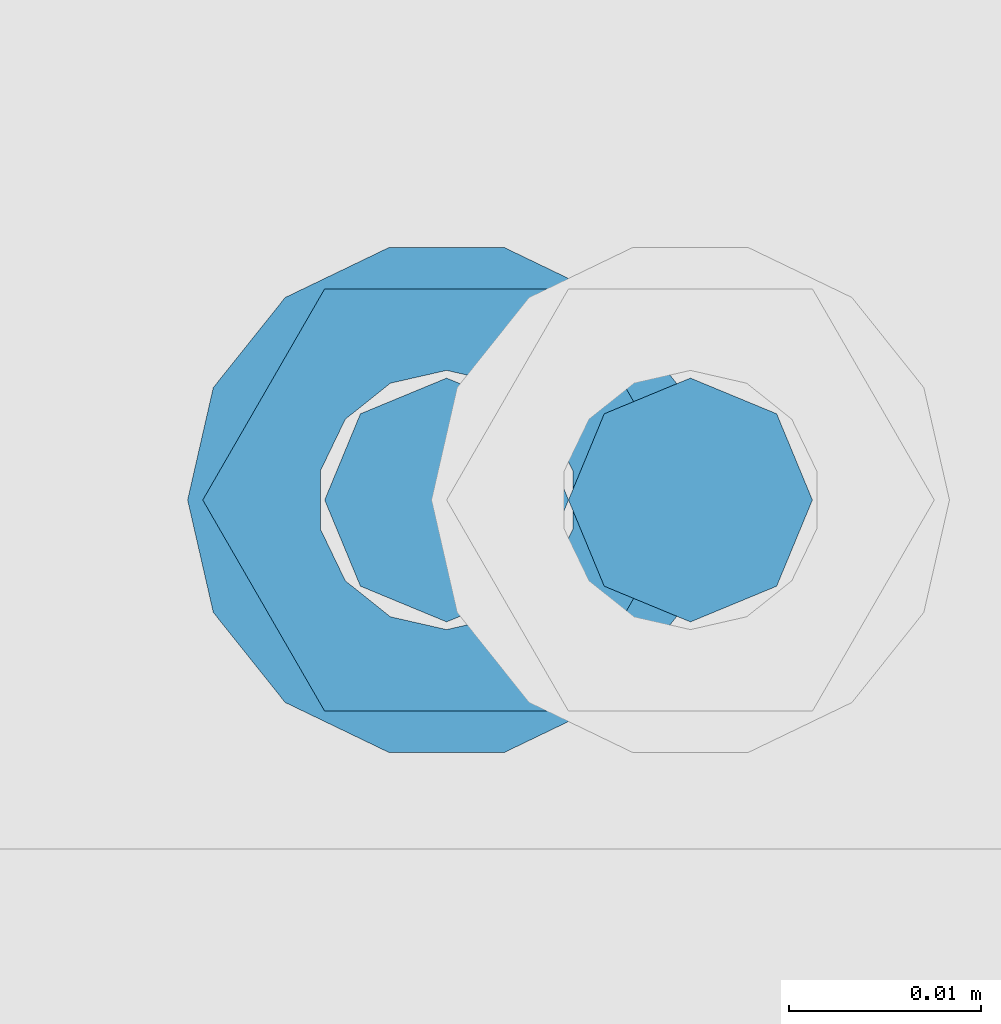
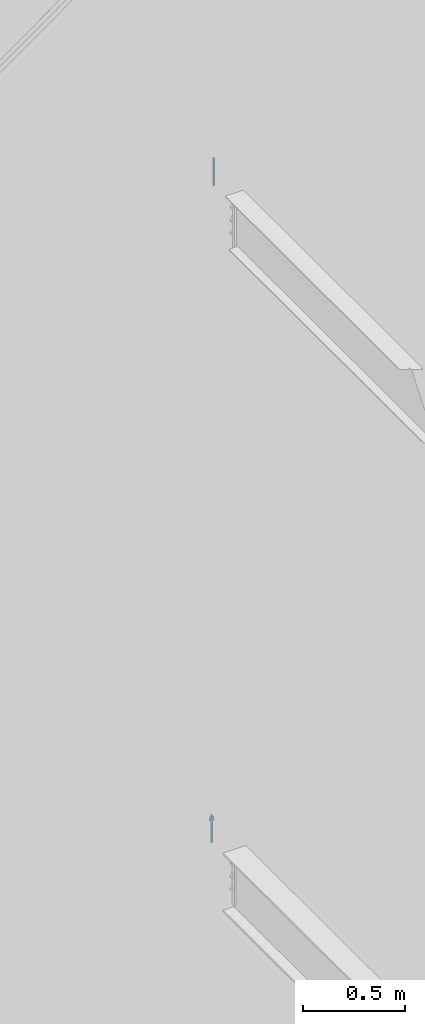
# One storey, part 564 of 1179: 2 columns, 2 elements without a shape of their own.
"""IFC2X3 building model written with IfcOpenShell, lengths in millimetres."""

import ifcopenshell
import ifcopenshell.guid

model = None  # the IFC model being written
_history = None  # IfcOwnerHistory: only IFC2X3 demands one
_inside = {}  # id of a spatial element -> (the spatial element, [elements in it])
_under = {}  # id of a project, library or spatial element -> (it, [spatial elements below it])
_declared = {}  # id of a project -> (the project, [libraries it declares])
_typed = {}  # id of a type object -> (the type object, [elements of that type])
_made_of = {}  # id of a material, layer set ... -> (it, [elements and type objects made of it])


def new_model(schema):
    """Start an empty IFC model of exactly this schema.

    Asked for "IFC4X3", IfcOpenShell would pick the latest addendum, in which some entities
    have other attributes; the version numbers below select the first issue.
    IFC2X3 requires an IfcOwnerHistory on every rooted entity: one is made here for all.
    """
    global model, _history
    if schema == "IFC4X3":
        model = ifcopenshell.file(schema_version=(4, 3, 0, 0))
    else:
        model = ifcopenshell.file(schema=schema)
    _inside.clear()
    _under.clear()
    _declared.clear()
    _typed.clear()
    _made_of.clear()
    _history = None
    if model.schema == "IFC2X3":
        org = make("IfcOrganization", Name="unknown")
        user = make(
            "IfcPersonAndOrganization",
            ThePerson=make("IfcPerson", FamilyName="unknown"),
            TheOrganization=org,
        )
        app = make(
            "IfcApplication",
            ApplicationDeveloper=org,
            Version="unknown",
            ApplicationFullName="unknown",
            ApplicationIdentifier="unknown",
        )
        _history = make(
            "IfcOwnerHistory",
            OwningUser=user,
            OwningApplication=app,
            ChangeAction="ADDED",
            CreationDate=0,
        )
    return model


def make(cls, **values):
    """One entity of the class cls with the attributes given. An attribute that is None is left unset."""
    return model.create_entity(
        cls, **{name: value for name, value in values.items() if value is not None}
    )


def rooted(cls, **values):
    """An entity with a GlobalId (a new one), such as an element, a storey or a relation."""
    return make(cls, GlobalId=ifcopenshell.guid.new(), OwnerHistory=_history, **values)


def si_unit(unit_type, name, prefix=None):
    """IfcSIUnit, for example si_unit("LENGTHUNIT", "METRE", prefix="MILLI")."""
    return make("IfcSIUnit", UnitType=unit_type, Prefix=prefix, Name=name)


def assignment(units):
    """IfcUnitAssignment: the units of a project."""
    return None if units is None else make("IfcUnitAssignment", Units=units)


def point(xyz):
    """IfcCartesianPoint."""
    return None if xyz is None else make("IfcCartesianPoint", Coordinates=xyz)


def direction(xyz):
    """IfcDirection."""
    return None if xyz is None else make("IfcDirection", DirectionRatios=xyz)


def frame(location, z_axis=None, x_axis=None):
    """IfcAxis2Placement3D, a coordinate frame: its origin and axes. An axis left out is left unset."""
    return make(
        "IfcAxis2Placement3D",
        Location=point(location),
        Axis=direction(z_axis),
        RefDirection=direction(x_axis),
    )


def origin_with_axes():
    """The frame at (0, 0, 0) with the z axis (0, 0, 1) and the x axis (1, 0, 0) written out."""
    return frame((0.0, 0.0, 0.0), z_axis=(0.0, 0.0, 1.0), x_axis=(1.0, 0.0, 0.0))


def place(relative_to, where):
    """IfcLocalPlacement: puts the frame where relative to a parent placement (None: the world)."""
    return make(
        "IfcLocalPlacement", PlacementRelTo=relative_to, RelativePlacement=where
    )


def context(
    kind, dimensions, precision=None, world=None, true_north=None, identifier=None
):
    """IfcGeometricRepresentationContext, for example the 3D "Model" context."""
    return make(
        "IfcGeometricRepresentationContext",
        ContextIdentifier=identifier,
        ContextType=kind,
        CoordinateSpaceDimension=dimensions,
        Precision=precision,
        WorldCoordinateSystem=world,
        TrueNorth=true_north,
    )


def subcontext(parent, identifier, kind, view, scale=None):
    """IfcGeometricRepresentationSubContext, for example "Body" below "Model"."""
    return make(
        "IfcGeometricRepresentationSubContext",
        ContextIdentifier=identifier,
        ContextType=kind,
        ParentContext=parent,
        TargetScale=scale,
        TargetView=view,
    )


def project(units=None, contexts=None):
    """IfcProject with its units and contexts."""
    return rooted(
        "IfcProject",
        Name="project",
        RepresentationContexts=contexts,
        UnitsInContext=assignment(units),
    )


def spatial(cls, under=None, at=None, **own):
    """A site, building, storey or space (cls), placed at a placement, below another one or the project."""
    s = rooted(cls, ObjectPlacement=at, **own)
    if under is not None:
        _under.setdefault(under.id(), (under, []))[1].append(s)
    return s


def faces_of(points, faces, orient=None, outer=None):
    """IfcFace entities. A face is a list of loops; a loop is a list of indices into points, from 0.

    orient and outer hold one flag for each loop. By default every Orientation is true, the
    first loop of a face is its IfcFaceOuterBound and the others are IfcFaceBound.
    """
    made = []
    for i, loops in enumerate(faces):
        bounds = []
        for j, loop in enumerate(loops):
            is_outer = j == 0 if outer is None else outer[i][j]
            bounds.append(
                make(
                    "IfcFaceOuterBound" if is_outer else "IfcFaceBound",
                    Bound=make("IfcPolyLoop", Polygon=[points[k] for k in loop]),
                    Orientation=True if orient is None else orient[i][j],
                )
            )
        made.append(make("IfcFace", Bounds=bounds))
    return made


def faceted_brep(points, faces, orient=None, outer=None, voids=None):
    """IfcFacetedBrep: a solid bounded by flat faces; with voids (closed shells), ...WithVoids."""
    shared = [point(p) for p in points]
    hull = make("IfcClosedShell", CfsFaces=faces_of(shared, faces, orient, outer))
    if voids is None:
        return make("IfcFacetedBrep", Outer=hull)
    return make(
        "IfcFacetedBrepWithVoids",
        Outer=hull,
        Voids=[
            make(cls, CfsFaces=faces_of(shared, fs, o, b)) for cls, fs, o, b in voids
        ],
    )


def shape(context_of_items, identifier, shape_type, items):
    """IfcShapeRepresentation: the items that make up one representation, for example the "Body"."""
    return make(
        "IfcShapeRepresentation",
        ContextOfItems=context_of_items,
        RepresentationIdentifier=identifier,
        RepresentationType=shape_type,
        Items=items,
    )


def material(Name=None, Category=None):
    """IfcMaterial."""
    return make("IfcMaterial", Name=Name, Category=Category)


def made_of(thing, what):
    """Note that an element or type object is made of a material, layer set ...; save() writes the relation."""
    if what is not None:
        _made_of.setdefault(what.id(), (what, []))[1].append(thing)
    return thing


def type_object(cls, material=None, **own):
    """A type object (cls), such as IfcWallType, which elements share."""
    return made_of(rooted(cls, **own), material)


def element(
    cls,
    number,
    at=None,
    inside=None,
    cuts=None,
    type_object=None,
    material=None,
    context=None,
    identifier="Body",
    shape_type=None,
    held_by="IfcProductDefinitionShape",
    body=None,
    shapes=None,
    **own,
):
    """One element of the class cls, such as IfcWall. Its Tag is "e" and its number.

    at: its placement. inside: the storey or other place that contains it. cuts: it is an
    opening in that element (IfcRelVoidsElement). A single representation is given by context,
    identifier, shape_type and body (its items); several are given by shapes. held_by: the class
    of the entity that holds the representations. save() writes the other relations.
    """
    e = rooted(cls, Tag="e%d" % number, ObjectPlacement=at, **own)
    if body is not None:
        shapes = [shape(context, identifier, shape_type, body)]
    if shapes is not None:
        e.Representation = make(held_by, Representations=shapes)
    if inside is not None:
        _inside.setdefault(inside.id(), (inside, []))[1].append(e)
    if cuts is not None:
        rooted(
            "IfcRelVoidsElement", RelatingBuildingElement=cuts, RelatedOpeningElement=e
        )
    if type_object is not None:
        _typed.setdefault(type_object.id(), (type_object, []))[1].append(e)
    return made_of(e, material)


def aggregate(whole, parts):
    """IfcRelAggregates: a whole, such as a stair, and the parts it consists of."""
    return rooted("IfcRelAggregates", RelatingObject=whole, RelatedObjects=parts)


def save(model, path):
    """Write the relations noted so far, then the file.

    IfcRelAggregates (storeys below a building ...), IfcRelContainedInSpatialStructure (elements
    in a storey), IfcRelDefinesByType, IfcRelAssociatesMaterial and IfcRelDeclares: one each for
    every whole, place, type object, material and project.
    """
    for whole, parts in _under.values():
        aggregate(whole, parts)
    for where, things in _inside.values():
        rooted(
            "IfcRelContainedInSpatialStructure",
            RelatedElements=things,
            RelatingStructure=where,
        )
    for kind, things in _typed.values():
        rooted("IfcRelDefinesByType", RelatedObjects=things, RelatingType=kind)
    for what, things in _made_of.values():
        rooted("IfcRelAssociatesMaterial", RelatedObjects=things, RelatingMaterial=what)
    for by, libraries in _declared.values():
        rooted("IfcRelDeclares", RelatingContext=by, RelatedDefinitions=libraries)
    model.write(path)


model = new_model("IFC2X3")

# Units and contexts
model_context = context("Model", 3, precision=1e-05, world=origin_with_axes())
body_context = subcontext(model_context, "Body", "Model", "MODEL_VIEW")
ifc_project = project(units=[si_unit("LENGTHUNIT", "METRE", prefix="MILLI"), si_unit("AREAUNIT", "SQUARE_METRE"), si_unit("VOLUMEUNIT", "CUBIC_METRE"), si_unit("MASSUNIT", "GRAM", prefix="KILO"), si_unit("TIMEUNIT", "SECOND"), si_unit("PLANEANGLEUNIT", "RADIAN"), si_unit("SOLIDANGLEUNIT", "STERADIAN"), si_unit("THERMODYNAMICTEMPERATUREUNIT", "DEGREE_CELSIUS"), si_unit("LUMINOUSINTENSITYUNIT", "LUMEN")], contexts=[model_context])

# Site, building, storey
site_placement = place(None, origin_with_axes())
site = spatial("IfcSite", under=ifc_project, at=site_placement, CompositionType="ELEMENT")
building_placement = place(site_placement, origin_with_axes())
building = spatial("IfcBuilding", under=site, at=building_placement, Name="Undefined", CompositionType="ELEMENT")
storey_placement = place(building_placement, origin_with_axes())
storey = spatial("IfcBuildingStorey", under=building, at=storey_placement, Name="Undefined", CompositionType="ELEMENT", Elevation=0.0)

# Assembly, column
assembly_1_placement = place(storey_placement, origin_with_axes())
assembly_1 = element("IfcElementAssembly", 1, at=assembly_1_placement, inside=storey, Name="BEAM", AssemblyPlace="NOTDEFINED", PredefinedType="RIGID_FRAME")
ifc_material = material(Name="STEEL/A307")
column_type = type_object("IfcColumnType", PredefinedType="NOTDEFINED")
column_1_placement = place(assembly_1_placement, frame((20317.221875, 37985.7, 8013.7), z_axis=(0.0, 1.0, 0.0), x_axis=(0.0, 0.0, 1.0)))
column_1 = element("IfcColumn", 2, at=column_1_placement, type_object=column_type, material=ifc_material, Name="THREADED ROD", context=body_context, shape_type="Brep", body=[
    faceted_brep([(0.0, -6.34999999999854, 0.0), (0.0, -4.49012806053361, -4.49012806053452), (163.512500000001, -4.49012806053361, -4.49012806053452), (163.512500000001, -6.34999999999854, 0.0), (0.0, 0.0, -6.34999999999991), (163.512500000001, 0.0, -6.35000000000036), (0.0, 4.49012806053361, -4.49012806053452), (163.512500000001, 4.49012806053361, -4.49012806053452), (0.0, 6.34999999999854, 0.0), (163.512500000001, 6.34999999999854, 0.0), (0.0, 4.49012806053361, 4.49012806053452), (163.512500000001, 4.49012806053361, 4.49012806053452), (0.0, 0.0, 6.34999999999991), (163.512500000001, 0.0, 6.35000000000036), (0.0, -4.49012806053361, 4.49012806053452), (163.512500000001, -4.49012806053361, 4.49012806053452)], [[[0, 1, 2, 3]], [[1, 4, 5, 2]], [[4, 6, 7, 5]], [[6, 8, 9, 7]], [[8, 10, 11, 9]], [[10, 12, 13, 11]], [[12, 14, 15, 13]], [[14, 0, 3, 15]], [[5, 7, 9, 11, 13, 15, 3, 2]], [[14, 12, 10, 8, 6, 4, 1, 0]]]),
])
aggregate(assembly_1, [column_1])

assembly_2_placement = place(storey_placement, origin_with_axes())
assembly_2 = element("IfcElementAssembly", 3, at=assembly_2_placement, inside=storey, Name="BEAM", AssemblyPlace="NOTDEFINED", PredefinedType="RIGID_FRAME")
column_2_placement = place(assembly_2_placement, frame((20304.521875, 37985.7, 4102.1), z_axis=(0.0, 1.0, 0.0), x_axis=(0.0, 0.0, 1.0)))
column_2 = element("IfcColumn", 4, at=column_2_placement, type_object=column_type, material=ifc_material, Name="THREADED ROD", context=body_context, shape_type="Brep", body=[
    faceted_brep([(0.0, -4.49012806053361, 4.49012806053452), (0.0, -6.34999999999854, 0.0), (163.512500000001, -6.34999999999854, 0.0), (163.512500000001, -4.49012806053361, 4.49012806053452), (0.0, 0.0, 6.34999999999991), (0.0, 4.49012806053361, 4.49012806053452), (0.0, 6.34999999999854, 0.0), (0.0, 4.49012806053361, -4.49012806053452), (0.0, 0.0, -6.34999999999991), (0.0, -4.49012806053361, -4.49012806053452), (163.512500000001, 0.0, 6.35000000000036), (163.512500000001, 4.49012806053361, 4.49012806053452), (163.512500000001, 6.34999999999854, 0.0), (163.512500000001, 4.49012806053361, -4.49012806053452), (163.512500000001, 0.0, -6.35000000000036), (163.512500000001, -4.49012806053361, -4.49012806053452), (133.349999999999, -12.1540698217887, -5.85309154138668), (133.349999999999, -8.41087728436833, -10.5469065195502), (138.112499999999, -8.41087728436833, -10.5469065195502), (138.112499999999, -12.1540698217887, -5.85309154138668), (133.349999999999, -3.00180734814057, -13.1517773121886), (138.112499999999, -3.00180734814057, -13.1517773121886), (133.349999999999, 3.00180734814057, -13.1517773121886), (138.112499999999, 3.00180734814057, -13.1517773121886), (133.349999999999, 8.41087728436833, -10.5469065195502), (138.112499999999, 8.41087728436833, -10.5469065195502), (133.349999999999, 12.1540698217887, -5.85309154138668), (138.112499999999, 12.1540698217887, -5.85309154138668), (133.349999999999, 13.4899997711182, 0.0), (138.112499999999, 13.4899997711182, 0.0), (133.349999999999, 12.1540698217887, 5.85309154138668), (138.112499999999, 12.1540698217887, 5.85309154138668), (133.349999999999, 8.41087728436833, 10.5469065195502), (138.112499999999, 8.41087728436833, 10.5469065195502), (133.349999999999, 3.00180734814057, 13.1517773121886), (138.112499999999, 3.00180734814057, 13.1517773121886), (133.349999999999, -3.00180734814057, 13.1517773121886), (138.112499999999, -3.00180734814057, 13.1517773121886), (133.349999999999, -8.41087728436833, 10.5469065195502), (138.112499999999, -8.41087728436833, 10.5469065195502), (133.349999999999, -12.1540698217887, 5.85309154138668), (138.112499999999, -12.1540698217887, 5.85309154138668), (133.349999999999, -13.4899997711182, 0.0), (138.112499999999, -13.4899997711182, 0.0), (138.112499999999, -12.6999998092651, 0.0), (138.112499999999, -6.34999990463257, 11.0), (138.112499999999, 6.34999990463257, 11.0), (138.112499999999, 12.6999998092651, 0.0), (138.112499999999, 6.34999990463257, -11.0), (138.112499999999, -6.34999990463257, -11.0), (133.349999999999, -2.92871523904432, 6.0815398583436), (133.349999999999, -5.27736250665839, 4.20855616254994), (133.349999999999, -6.58076340722801, 1.50201630420634), (133.349999999999, -6.58076340722801, -1.50201630420634), (133.349999999999, -5.27736250665839, -4.20855616254994), (133.349999999999, -2.92871523904432, -6.0815398583436), (133.349999999999, 0.0, -6.75), (133.349999999999, 2.92871523904432, -6.0815398583436), (133.349999999999, 5.27736250665839, -4.20855616254994), (133.349999999999, 6.58076340722801, -1.50201630420634), (133.349999999999, 6.58076340722801, 1.50201630420634), (133.349999999999, 5.27736250665839, 4.20855616254994), (133.349999999999, 2.92871523904432, 6.0815398583436), (133.349999999999, 0.0, 6.75), (150.812499999999, -2.92871523904432, 6.0815398583436), (150.812499999999, 0.0, 6.75), (150.812499999999, -5.27736250665839, 4.20855616254994), (150.812499999999, -6.58076340722801, 1.50201630420634), (150.812499999999, -5.27736250665839, -4.20855616254994), (150.812499999999, -6.58076340722801, -1.50201630420634), (150.812499999999, -2.92871523904432, -6.0815398583436), (150.812499999999, 0.0, -6.75), (150.812499999999, 2.92871523904432, -6.0815398583436), (150.812499999999, 5.27736250665839, -4.20855616254994), (150.812499999999, 6.58076340722801, -1.50201630420634), (150.812499999999, 5.27736250665839, 4.20855616254994), (150.812499999999, 6.58076340722801, 1.50201630420634), (150.812499999999, 2.92871523904432, 6.0815398583436), (150.812499999999, -12.6999998092651, 0.0), (150.812499999999, -6.34999990463257, 11.0), (150.812499999999, 6.34999990463257, -11.0), (150.812499999999, -6.34999990463257, -11.0), (150.812499999999, 12.6999998092651, 0.0), (150.812499999999, 6.34999990463257, 11.0)], [[[0, 1, 2, 3]], [[0, 4, 5, 6, 7, 8, 9, 1]], [[5, 4, 10, 11]], [[6, 5, 11, 12]], [[7, 6, 12, 13]], [[8, 7, 13, 14]], [[9, 8, 14, 15]], [[1, 9, 15, 2]], [[14, 13, 12, 11, 10, 3, 2, 15]], [[4, 0, 3, 10]], [[16, 17, 18, 19]], [[17, 20, 21, 18]], [[20, 22, 23, 21]], [[22, 24, 25, 23]], [[24, 26, 27, 25]], [[26, 28, 29, 27]], [[28, 30, 31, 29]], [[30, 32, 33, 31]], [[32, 34, 35, 33]], [[34, 36, 37, 35]], [[36, 38, 39, 37]], [[38, 40, 41, 39]], [[40, 42, 43, 41]], [[18, 21, 23, 25, 27, 29, 31, 33, 35, 37, 39, 41, 43, 19], [44, 45, 46, 47, 48, 49]], [[42, 16, 19, 43]], [[40, 38, 36, 34, 32, 30, 28, 26, 24, 22, 20, 17, 16, 42], [50, 51, 52, 53, 54, 55, 56, 57, 58, 59, 60, 61, 62, 63]], [[64, 50, 63, 65]], [[66, 51, 50, 64]], [[67, 52, 51, 66]], [[68, 54, 53, 69]], [[70, 55, 54, 68]], [[71, 56, 55, 70]], [[72, 57, 56, 71]], [[73, 58, 57, 72]], [[74, 59, 58, 73]], [[75, 61, 60, 76]], [[77, 62, 61, 75]], [[77, 65, 63, 62]], [[78, 79, 45, 44]], [[80, 81, 49, 48]], [[82, 80, 48, 47]], [[83, 82, 47, 46]], [[79, 83, 46, 45]], [[81, 78, 44, 49]], [[53, 52, 67, 69]], [[60, 59, 74, 76]], [[80, 82, 83, 79, 78, 81], [75, 76, 74, 73, 72, 71, 70, 68, 69, 67, 66, 64, 65, 77]]]),
])
aggregate(assembly_2, [column_2])

save(model, "model.ifc")
